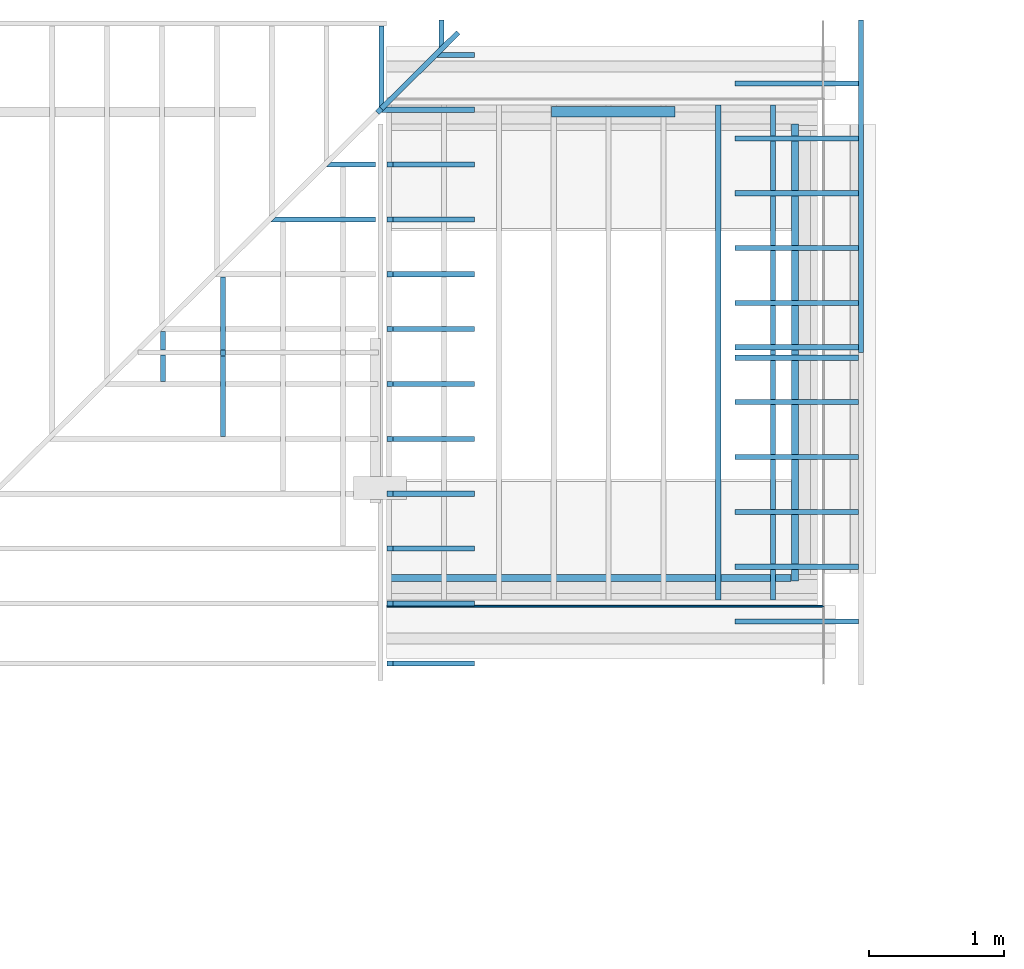
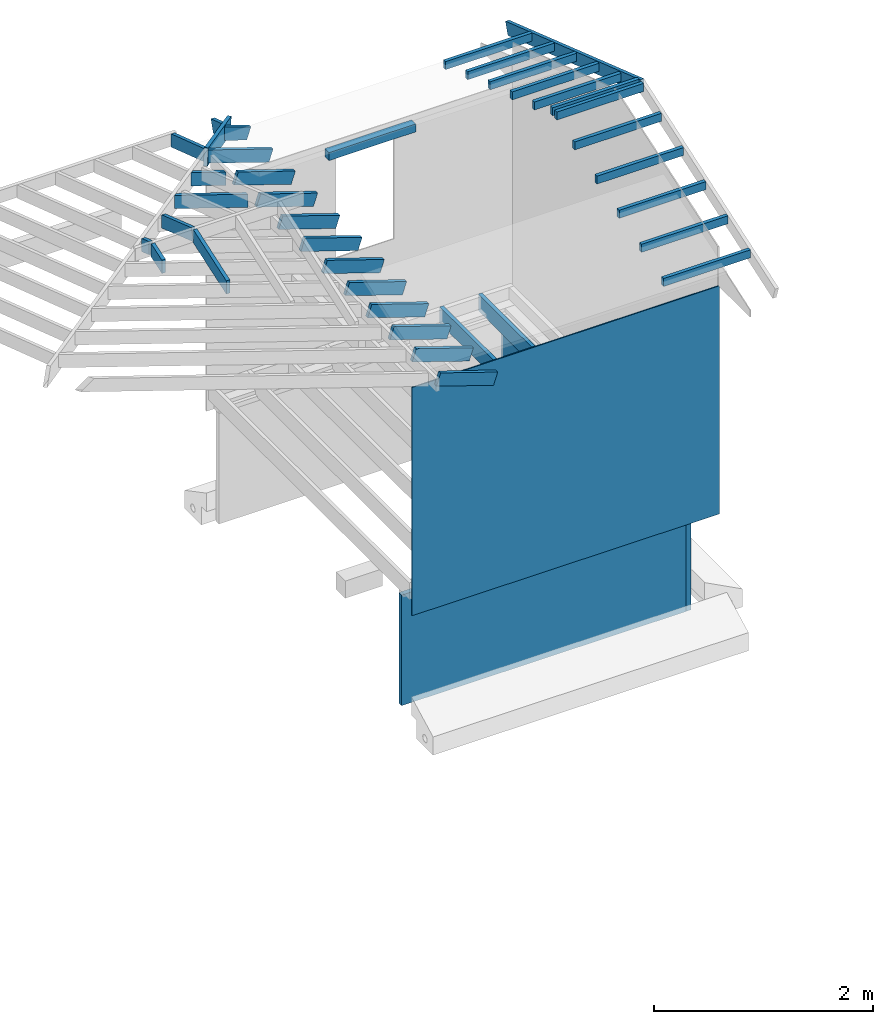
# Not in any storey, part 3 of 8: 37 beams, 3 walls.
"""IFC4 model written with IfcOpenShell, lengths in feet."""

from ifc_helpers import new_model, entity, si_unit, converted_unit, frame, origin_with_axes, origin_2d_with_axis, place, context, subcontext, project, indexed_curve, rectangle, outline, extrude, clip, halfspace, material, layer, layer_set, layer_usage, material_profile, profile_set, profile_usage, type_object, element, save


model = new_model("IFC4")

# Units and contexts
model_context = context("Model", 3, precision=1e-05, world=origin_with_axes())
plan_context = context("Plan", 2, precision=1e-05, world=origin_2d_with_axis())
context_of_model_1 = context(None, 3, precision=1e-05, world=origin_with_axes())
context_of_model_2 = context(None, 3, precision=1e-05, world=origin_with_axes())
body_context = subcontext(model_context, "Body", "Model", "MODEL_VIEW")
ifc_project = project(units=[converted_unit("PLANEANGLEUNIT", "degree", entity("IfcReal", 0.0174532925199433), si_unit("PLANEANGLEUNIT", "RADIAN"), dimensions=[0, 0, 0, 0, 0, 0, 0]), converted_unit("AREAUNIT", "square foot", entity("IfcReal", 0.09290304), si_unit("AREAUNIT", "SQUARE_METRE"), dimensions=[2, 0, 0, 0, 0, 0, 0]), converted_unit("LENGTHUNIT", "foot", entity("IfcReal", 0.3048), si_unit("LENGTHUNIT", "METRE"), dimensions=[1, 0, 0, 0, 0, 0, 0]), converted_unit("VOLUMEUNIT", "cubic foot", entity("IfcReal", 0.0283168467116885), si_unit("VOLUMEUNIT", "CUBIC_METRE"), dimensions=[3, 0, 0, 0, 0, 0, 0])], contexts=[model_context, plan_context, context_of_model_1, context_of_model_2])

# Beams
ifc_material_1 = material(Name="(2) 2X4 HEADER", Category="wood3")
ifc_material_profile_1 = material_profile(ifc_material_1, rectangle(XDim=0.25, YDim=0.291667014360428))
ifc_profile_set_1 = profile_set([ifc_material_profile_1])
ifc_profile_usage_1 = profile_usage(ifc_profile_set_1, cardinal=5)
beam_type_1 = type_object("IfcBeamType", Name="2X4", PredefinedType="BEAM", material=ifc_profile_set_1)
beam_1_placement = place(None, frame((-6.91529021175515, 8.83884473735579, 7.00261883848295), z_axis=(0.999999999999994, -7.54979012640429e-08, 7.54979012640429e-08), x_axis=(7.54979012640431e-08, 0.999999999999997, 7.16093850883224e-15)))
element("IfcBeam", 1, at=beam_1_placement, type_object=beam_type_1, material=ifc_profile_usage_1, Name="Beam", context=body_context, shape_type="SweptSolid", body=[
    extrude(rectangle(XDim=0.25, YDim=0.291667014360428), origin_with_axes(), (0.0, 0.0, 1.0), 2.99999953782462),
])
ifc_material_2 = material(Name="006")
ifc_material_profile_2 = material_profile(ifc_material_2, rectangle(XDim=0.125, YDim=0.604166686534882))
ifc_profile_set_2 = profile_set([ifc_material_profile_2])
ifc_profile_usage_2 = profile_usage(ifc_profile_set_2, cardinal=5)
beam_type_2 = type_object("IfcBeamType", Name="2x8", PredefinedType="BEAM", material=ifc_profile_set_2)
beam_2_placement = place(None, frame((-11.0968407683485, 8.86157663475497, 8.36714202650576), z_axis=(0.691535772575133, 0.685647846935964, -0.227300033526156), x_axis=(-0.704077230942166, 0.710123406788434, -2.06514179758879e-08)))
element("IfcBeam", 2, at=beam_2_placement, type_object=beam_type_2, material=ifc_profile_usage_2, Name="Beam", context=body_context, shape_type="SweptSolid", body=[
    extrude(rectangle(XDim=0.125, YDim=0.604166686534882), origin_with_axes(), (0.0, 0.0, 1.0), 2.69892431940406),
])
ifc_material_3 = material(Category="wood3")
ifc_material_profile_3 = material_profile(ifc_material_3, rectangle(XDim=0.125, YDim=0.458299994468689))
ifc_profile_set_3 = profile_set([ifc_material_profile_3])
ifc_profile_usage_3 = profile_usage(ifc_profile_set_3, cardinal=5)
beam_type_3 = type_object("IfcBeamType", Name="2x6 RAFTER", PredefinedType="BEAM", material=ifc_profile_set_3)
beam_3_placement = place(None, frame((-9.58749080893249, 10.9906905279385, 7.70176020194226), z_axis=(-1.19209318326683e-07, -0.948710682826727, 0.316145599827723), x_axis=(0.999999999999993, -1.13095140363838e-07, 3.76875242125149e-08)))
element("IfcBeam", 3, at=beam_3_placement, type_object=beam_type_3, material=ifc_profile_usage_3, Name="Beam", context=body_context, shape_type="Clipping", body=[
    clip(extrude(rectangle(XDim=0.125, YDim=0.458299994468689), origin_with_axes(), (0.0, 0.0, 1.0), 1.03234392450725), halfspace(frame((-1.5533548288458, -0.0278237141336356, 2.18816512212979), z_axis=(0.704077363014221, -0.224502399563789, 0.673701584339142), x_axis=(-0.303790687835165, -0.952738798404178, 0.0)), False)),
])
ifc_profile_usage_4 = profile_usage(ifc_profile_set_3, cardinal=5)
beam_4_placement = place(None, frame((-11.0458224777162, 11.3530398353817, 7.58101229905456), z_axis=(-1.19209318326683e-07, -0.948710682826727, 0.316145599827723), x_axis=(0.999999999999993, -1.13095140363838e-07, 3.76875313179423e-08)))
element("IfcBeam", 4, at=beam_4_placement, type_object=beam_type_3, material=ifc_profile_usage_4, Name="Beam", context=body_context, shape_type="Clipping", body=[
    clip(clip(extrude(rectangle(XDim=0.125, YDim=0.458299994468689), origin_with_axes(), (0.0, 0.0, 1.0), 2.93836754041396), halfspace(frame((0.127243242297429, 0.0117523620134889, 0.462216175994848), z_axis=(-2.36881696480395e-08, 0.316145688295364, -0.948710680007935), x_axis=(0.999999999999997, 7.49280174458948e-08, 0.0)), False)), halfspace(frame((-0.0950231661731646, -0.0278237141336356, 2.57010261217753), z_axis=(0.704077363014221, -0.224502399563789, 0.673701584339142), x_axis=(-0.303790687835165, -0.952738798404178, 0.0)), False)),
])
ifc_profile_usage_5 = profile_usage(ifc_profile_set_3, cardinal=5)
beam_5_placement = place(None, frame((-8.85837503618456, 0.884866640167286, 7.65647709838987), z_axis=(-0.948710650053447, -1.9780097822792e-07, 0.3161456981759), x_axis=(-1.62920684942943e-07, 0.999999999999977, 1.36760945679268e-07)))
element("IfcBeam", 5, at=beam_5_placement, type_object=beam_type_3, material=ifc_profile_usage_5, Name="Beam", context=body_context, shape_type="SweptSolid", body=[
    extrude(rectangle(XDim=0.125, YDim=0.458299994468689), origin_with_axes(), (0.0, 0.0, 1.0), 2.08211565102715),
])
ifc_profile_usage_6 = profile_usage(ifc_profile_set_3, cardinal=5)
beam_6_placement = place(None, frame((-8.85837503618456, -0.448466579275807, 7.65647709838987), z_axis=(-0.948710650053447, -1.9780097822792e-07, 0.3161456981759), x_axis=(-1.62920684942943e-07, 0.999999999999977, 1.36760945679268e-07)))
element("IfcBeam", 6, at=beam_6_placement, type_object=beam_type_3, material=ifc_profile_usage_6, Name="Beam", context=body_context, shape_type="SweptSolid", body=[
    extrude(rectangle(XDim=0.125, YDim=0.458299994468689), origin_with_axes(), (0.0, 0.0, 1.0), 2.08211470735415),
])
ifc_profile_usage_7 = profile_usage(ifc_profile_set_3, cardinal=5)
beam_7_placement = place(None, frame((-8.85837503618456, -1.78179970094225, 7.65647709838987), z_axis=(-0.948710650053447, -1.9780097822792e-07, 0.3161456981759), x_axis=(-1.62920684942943e-07, 0.999999999999977, 1.36760945679268e-07)))
element("IfcBeam", 7, at=beam_7_placement, type_object=beam_type_3, material=ifc_profile_usage_7, Name="Beam", context=body_context, shape_type="SweptSolid", body=[
    extrude(rectangle(XDim=0.125, YDim=0.458299994468689), origin_with_axes(), (0.0, 0.0, 1.0), 2.08211470735415),
])
ifc_profile_usage_8 = profile_usage(ifc_profile_set_3, cardinal=5)
beam_8_placement = place(None, frame((-8.85837503618456, 10.2182002518121, 7.65647709838987), z_axis=(-0.948710650053447, -1.9780097822792e-07, 0.3161456981759), x_axis=(-1.62920684942943e-07, 0.999999999999977, 1.36760945679268e-07)))
element("IfcBeam", 8, at=beam_8_placement, type_object=beam_type_3, material=ifc_profile_usage_8, Name="Beam", context=body_context, shape_type="Clipping", body=[
    clip(extrude(rectangle(XDim=0.125, YDim=0.458299994468689), origin_with_axes(), (0.0, 0.0, 1.0), 1.28196848188352), halfspace(frame((-1.40100619767907, 0.0195536521700971, 2.30658222527642), z_axis=(0.710123538970947, 0.22259096801281, 0.667965590953827), x_axis=(0.299104099787267, -0.954220486832288, 0.0)), False)),
])
ifc_profile_usage_9 = profile_usage(ifc_profile_set_3, cardinal=5)
beam_9_placement = place(None, frame((-8.85837503618456, 7.55153224849951, 7.65647709838987), z_axis=(-0.948710650053447, -1.9780097822792e-07, 0.3161456981759), x_axis=(-1.62920684942943e-07, 0.999999999999977, 1.36760945679268e-07)))
element("IfcBeam", 9, at=beam_9_placement, type_object=beam_type_3, material=ifc_profile_usage_9, Name="Beam", context=body_context, shape_type="SweptSolid", body=[
    extrude(rectangle(XDim=0.125, YDim=0.458299994468689), origin_with_axes(), (0.0, 0.0, 1.0), 2.08211642137209),
])
ifc_profile_usage_10 = profile_usage(ifc_profile_set_3, cardinal=5)
beam_10_placement = place(None, frame((-8.85837503618456, 8.88486625015579, 7.65647709838987), z_axis=(-0.948710650053447, -1.9780097822792e-07, 0.3161456981759), x_axis=(-1.62920684942943e-07, 0.999999999999977, 1.36760945679268e-07)))
element("IfcBeam", 10, at=beam_10_placement, type_object=beam_type_3, material=ifc_profile_usage_10, Name="Beam", context=body_context, shape_type="Clipping", body=[
    clip(extrude(rectangle(XDim=0.125, YDim=0.458299994468689), origin_with_axes(), (0.0, 0.0, 1.0), 2.6994550511993), halfspace(frame((-0.0676714260316896, 0.0195536521700971, 2.30658222527642), z_axis=(0.710123538970947, 0.22259096801281, 0.667965590953827), x_axis=(0.299104099787267, -0.954220486832288, 0.0)), False)),
])
ifc_profile_usage_11 = profile_usage(ifc_profile_set_3, cardinal=5)
beam_11_placement = place(None, frame((-8.85837503618456, 4.88486659182651, 7.65647709838987), z_axis=(-0.948710650053447, -1.9780097822792e-07, 0.3161456981759), x_axis=(-1.62920684942943e-07, 0.999999999999977, 1.36760945679268e-07)))
element("IfcBeam", 11, at=beam_11_placement, type_object=beam_type_3, material=ifc_profile_usage_11, Name="Beam", context=body_context, shape_type="SweptSolid", body=[
    extrude(rectangle(XDim=0.125, YDim=0.458299994468689), origin_with_axes(), (0.0, 0.0, 1.0), 2.08211642137213),
])
ifc_profile_usage_12 = profile_usage(ifc_profile_set_3, cardinal=5)
beam_12_placement = place(None, frame((-8.85837503618456, 3.55153298127683, 7.65647709838987), z_axis=(-0.948710650053447, -1.9780097822792e-07, 0.3161456981759), x_axis=(-1.62920684942943e-07, 0.999999999999977, 1.36760945679268e-07)))
element("IfcBeam", 12, at=beam_12_placement, type_object=beam_type_3, material=ifc_profile_usage_12, Name="Beam", context=body_context, shape_type="SweptSolid", body=[
    extrude(rectangle(XDim=0.125, YDim=0.458299994468689), origin_with_axes(), (0.0, 0.0, 1.0), 2.08211565102715),
])
ifc_profile_usage_13 = profile_usage(ifc_profile_set_3, cardinal=5)
beam_13_placement = place(None, frame((-8.85837503618456, 2.21820034849362, 7.65647709838987), z_axis=(-0.948710650053447, -1.9780097822792e-07, 0.3161456981759), x_axis=(-1.62920684942943e-07, 0.999999999999977, 1.36760945679268e-07)))
element("IfcBeam", 13, at=beam_13_placement, type_object=beam_type_3, material=ifc_profile_usage_13, Name="Beam", context=body_context, shape_type="SweptSolid", body=[
    extrude(rectangle(XDim=0.125, YDim=0.458299994468689), origin_with_axes(), (0.0, 0.0, 1.0), 2.08211565102715),
])
ifc_profile_usage_14 = profile_usage(ifc_profile_set_3, cardinal=5)
beam_14_placement = place(None, frame((-8.85837503618456, -3.11513272483205, 7.65647709838987), z_axis=(-0.948710650053447, -1.9780097822792e-07, 0.3161456981759), x_axis=(-1.62920684942943e-07, 0.999999999999977, 1.36760945679268e-07)))
element("IfcBeam", 14, at=beam_14_placement, type_object=beam_type_3, material=ifc_profile_usage_14, Name="Beam", context=body_context, shape_type="SweptSolid", body=[
    extrude(rectangle(XDim=0.125, YDim=0.458299994468689), origin_with_axes(), (0.0, 0.0, 1.0), 2.08211470735415),
])
ifc_profile_usage_15 = profile_usage(ifc_profile_set_3, cardinal=5)
beam_15_placement = place(None, frame((-8.85837503618456, -4.57346634914869, 7.65647709838987), z_axis=(-0.94871061429891, -1.66479323476969e-07, 0.316145805470447), x_axis=(-1.62920684942944e-07, 0.999999999999986, 3.7687520659801e-08)))
element("IfcBeam", 15, at=beam_15_placement, type_object=beam_type_3, material=ifc_profile_usage_15, Name="Beam", context=body_context, shape_type="SweptSolid", body=[
    extrude(rectangle(XDim=0.125, YDim=0.458299994468689), origin_with_axes(), (0.0, 0.0, 1.0), 2.08211495771642),
])
ifc_profile_usage_16 = profile_usage(ifc_profile_set_3, cardinal=5)
beam_16_placement = place(None, frame((-10.7543893999315, 7.55153224849951, 8.28829963063318), z_axis=(-0.948710682826718, -1.82218031427762e-07, 0.316145599827721), x_axis=(-1.62920684942944e-07, 0.999999999999983, 8.74705818887363e-08)))
element("IfcBeam", 16, at=beam_16_placement, type_object=beam_type_3, material=ifc_profile_usage_16, Name="Beam", context=body_context, shape_type="Clipping", body=[
    clip(clip(extrude(rectangle(XDim=0.125, YDim=0.458299994468689), origin_with_axes(), (0.0, 0.0, 1.0), 2.11842334462929), halfspace(frame((-12.5391229869812, 0.0239981431880687, 0.450306198024374), z_axis=(-3.13916473260178e-07, -0.316145569086075, -0.94871062040329), x_axis=(-0.999999999999507, 9.92949147342172e-07, 0.0)), False)), halfspace(frame((1.2656610234203, 0.0195532610635041, 0.308064250104384), z_axis=(0.710123538970947, 0.22259096801281, 0.667965531349182), x_axis=(0.299104099787267, -0.954220486832288, 0.0)), False)),
])
ifc_profile_usage_17 = profile_usage(ifc_profile_set_3, cardinal=5)
beam_17_placement = place(None, frame((-10.7543893999315, 6.21819942016301, 8.28829963063318), z_axis=(-0.948710682826718, -1.82218031427762e-07, 0.316145599827721), x_axis=(-1.62920684942944e-07, 0.999999999999983, 8.74705818887363e-08)))
element("IfcBeam", 17, at=beam_17_placement, type_object=beam_type_3, material=ifc_profile_usage_17, Name="Beam", context=body_context, shape_type="Clipping", body=[
    clip(clip(extrude(rectangle(XDim=0.125, YDim=0.458299994468689), origin_with_axes(), (0.0, 0.0, 1.0), 3.53590986171043), halfspace(frame((-11.2057897675382, 0.0239985342946617, 0.450306198024374), z_axis=(-3.13916473260178e-07, -0.316145569086075, -0.94871062040329), x_axis=(-0.999999999999507, 9.92949147342172e-07, 0.0)), False)), halfspace(frame((2.59899424286339, 0.0195536521700971, 0.308064250104384), z_axis=(0.710123538970947, 0.22259096801281, 0.667965531349182), x_axis=(0.299104099787267, -0.954220486832288, 0.0)), False)),
])
ifc_profile_usage_18 = profile_usage(ifc_profile_set_3, cardinal=5)
beam_18_placement = place(None, frame((-8.85837503618456, 6.2181998112696, 7.65647709838987), z_axis=(-0.948710650053447, -1.9780097822792e-07, 0.3161456981759), x_axis=(-1.62920684942943e-07, 0.999999999999977, 1.36760945679268e-07)))
element("IfcBeam", 18, at=beam_18_placement, type_object=beam_type_3, material=ifc_profile_usage_18, Name="Beam", context=body_context, shape_type="SweptSolid", body=[
    extrude(rectangle(XDim=0.125, YDim=0.458299994468689), origin_with_axes(), (0.0, 0.0, 1.0), 2.08211642137213),
])
ifc_material_4 = material(Category="wood3")
ifc_material_profile_4 = material_profile(ifc_material_4, rectangle(XDim=0.125, YDim=0.291666656732559))
ifc_profile_set_4 = profile_set([ifc_material_profile_4])
ifc_profile_usage_19 = profile_usage(ifc_profile_set_4, cardinal=5)
beam_type_4 = type_object("IfcBeamType", Name="2x4", PredefinedType="BEAM", material=ifc_profile_set_4)
beam_19_placement = place(None, frame((-2.45551600700288, -3.55546008257728, 8.31366993310883), z_axis=(0.999999999999998, 4.37113882867378e-08, -4.37113882867378e-08), x_axis=(-4.37113882867379e-08, 0.999999999999999, 0.0)))
element("IfcBeam", 19, at=beam_19_placement, type_object=beam_type_4, material=ifc_profile_usage_19, Name="Beam", context=body_context, shape_type="SweptSolid", body=[
    extrude(rectangle(XDim=0.125, YDim=0.291666656732559), origin_with_axes(), (0.0, 0.0, 1.0), 2.99999932396489),
])
ifc_profile_usage_20 = profile_usage(ifc_profile_set_4, cardinal=5)
beam_20_placement = place(None, frame((-2.45551600700288, -2.22212999198693, 8.75367032574231), z_axis=(0.999999999999998, 4.37113882867378e-08, -4.37113882867378e-08), x_axis=(-4.37113882867379e-08, 0.999999999999999, 0.0)))
element("IfcBeam", 20, at=beam_20_placement, type_object=beam_type_4, material=ifc_profile_usage_20, Name="Beam", context=body_context, shape_type="SweptSolid", body=[
    extrude(rectangle(XDim=0.125, YDim=0.291666656732559), origin_with_axes(), (0.0, 0.0, 1.0), 2.9999993239649),
])
ifc_profile_usage_21 = profile_usage(ifc_profile_set_4, cardinal=5)
beam_21_placement = place(None, frame((-2.45551620255618, -0.888799901396584, 9.19367071837578), z_axis=(0.999999999999998, 4.37113882867378e-08, -4.37113882867378e-08), x_axis=(-4.37113882867379e-08, 0.999999999999999, 0.0)))
element("IfcBeam", 21, at=beam_21_placement, type_object=beam_type_4, material=ifc_profile_usage_21, Name="Beam", context=body_context, shape_type="SweptSolid", body=[
    extrude(rectangle(XDim=0.125, YDim=0.291666656732559), origin_with_axes(), (0.0, 0.0, 1.0), 2.99999932396489),
])
ifc_profile_usage_22 = profile_usage(ifc_profile_set_4, cardinal=5)
beam_22_placement = place(None, frame((-2.45551620255618, 0.444530189193766, 9.63367032879607), z_axis=(0.999999999999998, 4.37113882867378e-08, -4.37113882867378e-08), x_axis=(-4.37113882867379e-08, 0.999999999999999, 0.0)))
element("IfcBeam", 22, at=beam_22_placement, type_object=beam_type_4, material=ifc_profile_usage_22, Name="Beam", context=body_context, shape_type="SweptSolid", body=[
    extrude(rectangle(XDim=0.125, YDim=0.291666656732559), origin_with_axes(), (0.0, 0.0, 1.0), 2.99999932396489),
])
ifc_profile_usage_23 = profile_usage(ifc_profile_set_4, cardinal=5)
beam_23_placement = place(None, frame((-2.45551620255618, 1.77786027978411, 10.0736699392164), z_axis=(0.999999999999998, 4.37113882867378e-08, -4.37113882867378e-08), x_axis=(-4.37113882867379e-08, 0.999999999999999, 0.0)))
element("IfcBeam", 23, at=beam_23_placement, type_object=beam_type_4, material=ifc_profile_usage_23, Name="Beam", context=body_context, shape_type="SweptSolid", body=[
    extrude(rectangle(XDim=0.125, YDim=0.291666656732559), origin_with_axes(), (0.0, 0.0, 1.0), 2.9999993239649),
])
ifc_profile_usage_24 = profile_usage(ifc_profile_set_4, cardinal=5)
beam_24_placement = place(None, frame((-2.45551620255618, 3.11119037037446, 10.5136703318498), z_axis=(0.999999999999998, 4.37113882867378e-08, -4.37113882867378e-08), x_axis=(-4.37113882867379e-08, 0.999999999999999, 0.0)))
element("IfcBeam", 24, at=beam_24_placement, type_object=beam_type_4, material=ifc_profile_usage_24, Name="Beam", context=body_context, shape_type="SweptSolid", body=[
    extrude(rectangle(XDim=0.125, YDim=0.291666656732559), origin_with_axes(), (0.0, 0.0, 1.0), 2.9999993239649),
])
ifc_profile_usage_25 = profile_usage(ifc_profile_set_4, cardinal=5)
beam_25_placement = place(None, frame((-2.45551561589629, 9.52241771177357, 8.31366993310883), z_axis=(0.999999999999998, 4.37113882867378e-08, -4.37113882867378e-08), x_axis=(-4.37113882867379e-08, 0.999999999999999, 0.0)))
element("IfcBeam", 25, at=beam_25_placement, type_object=beam_type_4, material=ifc_profile_usage_25, Name="Beam", context=body_context, shape_type="SweptSolid", body=[
    extrude(rectangle(XDim=0.125, YDim=0.291666656732559), origin_with_axes(), (0.0, 0.0, 1.0), 2.99999932396489),
])
ifc_profile_usage_26 = profile_usage(ifc_profile_set_4, cardinal=5)
beam_26_placement = place(None, frame((-2.45551542034299, 8.18908762118322, 8.75367032574231), z_axis=(0.999999999999998, 4.37113882867378e-08, -4.37113882867378e-08), x_axis=(-4.37113882867379e-08, 0.999999999999999, 0.0)))
element("IfcBeam", 26, at=beam_26_placement, type_object=beam_type_4, material=ifc_profile_usage_26, Name="Beam", context=body_context, shape_type="SweptSolid", body=[
    extrude(rectangle(XDim=0.125, YDim=0.291666656732559), origin_with_axes(), (0.0, 0.0, 1.0), 2.99999932396489),
])
ifc_profile_usage_27 = profile_usage(ifc_profile_set_4, cardinal=5)
beam_27_placement = place(None, frame((-2.45551542034299, 6.85575753059287, 9.19367071837578), z_axis=(0.999999999999998, 4.37113882867378e-08, -4.37113882867378e-08), x_axis=(-4.37113882867379e-08, 0.999999999999999, 0.0)))
element("IfcBeam", 27, at=beam_27_placement, type_object=beam_type_4, material=ifc_profile_usage_27, Name="Beam", context=body_context, shape_type="SweptSolid", body=[
    extrude(rectangle(XDim=0.125, YDim=0.291666656732559), origin_with_axes(), (0.0, 0.0, 1.0), 2.99999932396489),
])
ifc_profile_usage_28 = profile_usage(ifc_profile_set_4, cardinal=5)
beam_28_placement = place(None, frame((-2.4555152247897, 5.52242744000252, 9.63367032879607), z_axis=(0.999999999999998, 4.37113882867378e-08, -4.37113882867378e-08), x_axis=(-4.37113882867379e-08, 0.999999999999999, 0.0)))
element("IfcBeam", 28, at=beam_28_placement, type_object=beam_type_4, material=ifc_profile_usage_28, Name="Beam", context=body_context, shape_type="SweptSolid", body=[
    extrude(rectangle(XDim=0.125, YDim=0.291666656732559), origin_with_axes(), (0.0, 0.0, 1.0), 2.99999932396489),
])
ifc_profile_usage_29 = profile_usage(ifc_profile_set_4, cardinal=5)
beam_29_placement = place(None, frame((-2.4555152247897, 4.18909734941217, 10.0736699392164), z_axis=(0.999999999999998, 4.37113882867378e-08, -4.37113882867378e-08), x_axis=(-4.37113882867379e-08, 0.999999999999999, 0.0)))
element("IfcBeam", 29, at=beam_29_placement, type_object=beam_type_4, material=ifc_profile_usage_29, Name="Beam", context=body_context, shape_type="SweptSolid", body=[
    extrude(rectangle(XDim=0.125, YDim=0.291666656732559), origin_with_axes(), (0.0, 0.0, 1.0), 2.99999932396489),
])
ifc_profile_usage_30 = profile_usage(ifc_profile_set_4, cardinal=5)
beam_30_placement = place(None, frame((-2.4555152247897, 2.85576725882182, 10.5136703318498), z_axis=(0.999999999999998, 4.37113882867378e-08, -4.37113882867378e-08), x_axis=(-4.37113882867379e-08, 0.999999999999999, 0.0)))
element("IfcBeam", 30, at=beam_30_placement, type_object=beam_type_4, material=ifc_profile_usage_30, Name="Beam", context=body_context, shape_type="SweptSolid", body=[
    extrude(rectangle(XDim=0.125, YDim=0.291666656732559), origin_with_axes(), (0.0, 0.0, 1.0), 2.9999993239649),
])
ifc_material_profile_5 = material_profile(ifc_material_3, rectangle(XDim=0.125, YDim=0.458299994468689))
ifc_profile_set_5 = profile_set([ifc_material_profile_5])
ifc_profile_usage_31 = profile_usage(ifc_profile_set_5, cardinal=5)
beam_type_5 = type_object("IfcBeamType", Name="2X6 BARGE RAFTER", PredefinedType="BEAM", material=ifc_profile_set_5)
beam_31_placement = place(None, frame((0.60698335252096, 10.9922221013567, 7.70260499218317), z_axis=(-1.19209299780676e-07, -0.946459136166883, 0.322823641585037), x_axis=(0.999999999999993, -1.12826732845405e-07, 3.84836056355195e-08)))
element("IfcBeam", 31, at=beam_31_placement, type_object=beam_type_5, material=ifc_profile_usage_31, Name="Beam", context=body_context, shape_type="Clipping", body=[
    clip(extrude(rectangle(XDim=0.125, YDim=0.458299994468689), origin_with_axes(), (0.0, 0.0, 1.0), 9.29358308608242), halfspace(frame((-0.606982472531126, 0.229148668410584, 8.5383825727648), z_axis=(-1.64691172699349e-07, -0.322770535945892, 0.946477353572845), x_axis=(-0.99999999999987, 5.10242275419266e-07, 0.0)), False)),
])
ifc_profile_usage_32 = profile_usage(ifc_profile_set_5, cardinal=5)
beam_32_placement = place(None, frame((-16.3513343791011, 3.92279404354846, 10.1138850835365), z_axis=(-1.19209291908779e-07, -0.946459133272804, 0.322823650069941), x_axis=(0.999999999999993, -1.12826725739978e-07, 3.84835772138101e-08)))
element("IfcBeam", 32, at=beam_32_placement, type_object=beam_type_5, material=ifc_profile_usage_32, Name="Beam", context=body_context, shape_type="Clipping", body=[
    clip(clip(extrude(rectangle(XDim=0.125, YDim=0.458299994468689), origin_with_axes(), (0.0, 0.0, 1.0), 1.38471427914114), halfspace(frame((5.65944537715962, -1.887579758962, -0.185528452315043), z_axis=(-2.6183835188931e-07, 0.322823762893677, -0.946459233760834), x_axis=(0.999999999999671, 8.11087602542633e-07, 0.0)), False)), halfspace(frame((-0.609198531375469, 0.0204070620336558, 0.933375102015618), z_axis=(-6.38255670537546e-09, -0.32282367348671, 0.946459233760834), x_axis=(-1.0, 1.97710305332927e-08, 0.0)), False)),
])
ifc_profile_usage_33 = profile_usage(ifc_profile_set_5, cardinal=5)
beam_33_placement = place(None, frame((-16.3513265569692, 1.84692031755222, 10.0457472751147), z_axis=(8.54136783382466e-07, 0.94649584365125, 0.322716002005138), x_axis=(-0.999999999999619, 8.6625152562159e-07, 1.06078672956715e-07)))
element("IfcBeam", 33, at=beam_33_placement, type_object=beam_type_5, material=ifc_profile_usage_33, Name="Beam", context=body_context, shape_type="Clipping", body=[
    clip(clip(extrude(rectangle(XDim=0.125, YDim=0.458299994468689), origin_with_axes(), (0.0, 0.0, 1.0), 1.59307535356382), halfspace(frame((-5.59693520150472, -1.80340599356674, -0.156581088939677), z_axis=(-1.0152631375604e-06, 0.322715908288956, -0.946495831012726), x_axis=(0.999999999995051, 3.14599656068494e-06, 0.0)), False)), halfspace(frame((0.609208455705267, 0.0213508098814001, 1.14205393578437), z_axis=(7.47042236071138e-07, -0.322715997695923, 0.946495831012726), x_axis=(-0.999999999997321, -2.31485963324642e-06, 0.0)), False)),
])
ifc_profile_usage_34 = profile_usage(ifc_profile_set_5, cardinal=5)
beam_34_placement = place(None, frame((-14.8930074035965, 5.25612765409815, 9.65910399053979), z_axis=(-1.19209291908779e-07, -0.946459133272804, 0.322823650069941), x_axis=(0.999999999999993, -1.12826725739978e-07, 3.84835772138101e-08)))
element("IfcBeam", 34, at=beam_34_placement, type_object=beam_type_5, material=ifc_profile_usage_34, Name="Beam", context=body_context, shape_type="Clipping", body=[
    clip(extrude(rectangle(XDim=0.125, YDim=0.458299994468689), origin_with_axes(), (0.0, 0.0, 1.0), 2.41333530858582), halfspace(frame((4.20111801054847, -1.4571489624464, -0.0387141719372488), z_axis=(-2.6183835188931e-07, 0.322823762893677, -0.946459233760834), x_axis=(0.999999999999671, 8.11087602542633e-07, 0.0)), False)),
])
ifc_profile_usage_35 = profile_usage(ifc_profile_set_5, cardinal=5)
beam_35_placement = place(None, frame((-14.8930027103174, 0.51358641367259, 9.59113435795301), z_axis=(8.54136783382466e-07, 0.94649584365125, 0.322716002005138), x_axis=(-0.999999999999619, 8.6625152562159e-07, 1.06078672956715e-07)))
element("IfcBeam", 35, at=beam_35_placement, type_object=beam_type_5, material=ifc_profile_usage_35, Name="Beam", context=body_context, shape_type="Clipping", body=[
    clip(extrude(rectangle(XDim=0.125, YDim=0.458299994468689), origin_with_axes(), (0.0, 0.0, 1.0), 2.62161099133974), halfspace(frame((-4.13861252817269, -1.3731145287749, -0.00987103617728108), z_axis=(-1.0152631375604e-06, 0.322715908288956, -0.946495831012726), x_axis=(0.999999999995051, 3.14599656068494e-06, 0.0)), False)),
])
ifc_material_5 = material(Category="wood3")
ifc_material_profile_6 = material_profile(ifc_material_5, rectangle(XDim=0.125, YDim=0.604166686534882))
ifc_profile_set_6 = profile_set([ifc_material_profile_6])
ifc_profile_usage_36 = profile_usage(ifc_profile_set_6, cardinal=5)
beam_type_6 = type_object("IfcBeamType", Name="2x8 JOIST", PredefinedType="BEAM", material=ifc_profile_set_6)
beam_36_placement = place(None, frame((-1.52539422740461, -3.03462421487323, -0.364615476819787), z_axis=(1.50995802528084e-07, 0.999999999999986, 7.54979012640422e-08), x_axis=(-0.999999999999989, 1.50995802528085e-07, 7.16093766179923e-15)))
element("IfcBeam", 36, at=beam_36_placement, type_object=beam_type_6, material=ifc_profile_usage_36, Name="Beam", context=body_context, shape_type="SweptSolid", body=[
    extrude(rectangle(XDim=0.125, YDim=0.604166686534882), origin_with_axes(), (0.0, 0.0, 1.0), 12.0362043017855),
])
ifc_profile_usage_37 = profile_usage(ifc_profile_set_6, cardinal=5)
beam_37_placement = place(None, frame((-2.8587244157716, -3.03462401931993, -0.364615476819787), z_axis=(1.50995802528084e-07, 0.999999999999986, 7.54979012640422e-08), x_axis=(-0.999999999999989, 1.50995802528085e-07, 1.00485924106347e-14)))
element("IfcBeam", 37, at=beam_37_placement, type_object=beam_type_6, material=ifc_profile_usage_37, Name="Beam", context=body_context, shape_type="SweptSolid", body=[
    extrude(rectangle(XDim=0.125, YDim=0.604166686534882), origin_with_axes(), (0.0, 0.0, 1.0), 12.0362043017855),
])

# Walls
ifc_material_6 = material(Name="SIDING", Category="siding")
ifc_layer_1 = layer(ifc_material_6, 0.0416669994592667)
ifc_layer_set_1 = layer_set([ifc_layer_1])
ifc_layer_usage_1 = layer_usage(ifc_layer_set_1, "AXIS2", "POSITIVE", 0.0)
wall_type_1 = type_object("IfcWallType", PredefinedType="STANDARD", material=ifc_layer_set_1)
wall_1_placement = place(None, frame((-10.9212237393136, -3.20128803178081, -1.16348227490903), z_axis=(0.0, 0.0, 1.0), x_axis=(1.0, 0.0, 0.0)))
element("IfcWall", 38, at=wall_1_placement, type_object=wall_type_1, material=ifc_layer_usage_1, Name="Wall", context=body_context, shape_type="Clipping", body=[
    clip(extrude(outline(indexed_curve([(0.0, 0.0), (0.0, 0.0416669994592667), (10.6354101016816, 0.0416669994592667), (10.6354101016816, 0.0), (0.0, 0.0)], self_intersect=False)), origin_with_axes(), (0.0, 0.0, 1.0), 8.34589007645454), halfspace(frame((10.6354108632706, 0.0, 1.16348227490903), z_axis=(0.707106173038483, 0.707107365131378, 0.0), x_axis=(0.707107377232754, -0.707106185139838, 0.0)), False)),
])
ifc_material_7 = material(Category="InsulationBattVert")
ifc_layer_2 = layer(ifc_material_7, 0.166666999459267, Category="Materials")
ifc_layer_set_2 = layer_set([ifc_layer_2], Name="poche")
ifc_layer_usage_2 = layer_usage(ifc_layer_set_2, "AXIS2", "POSITIVE", 0.0)
wall_type_2 = type_object("IfcWallType", Name="EPS INSULATION", PredefinedType="STANDARD", material=ifc_layer_set_2)
wall_2_placement = place(None, frame((-10.9212276503796, -2.5762910917988, -4.83333204049138), z_axis=(0.0, 0.0, 1.0), x_axis=(1.0, 0.0, 0.0)))
element("IfcWall", 39, at=wall_2_placement, type_object=wall_type_2, material=ifc_layer_usage_2, Name="Wall", context=body_context, shape_type="SweptSolid", body=[
    extrude(outline(indexed_curve([(0.0, 0.0), (0.0, 0.166666999459267), (9.83333899973922, 0.166666999459267), (9.83333899973922, 0.0), (0.0, 0.0)], self_intersect=False)), origin_with_axes(), (0.0, 0.0, 1.0), 4.041670110282),
])
ifc_layer_usage_3 = layer_usage(ifc_layer_set_2, "AXIS2", "POSITIVE", 0.0)
wall_3_placement = place(None, frame((-0.910809522695116, -2.56587122994771, -4.83333204049138), z_axis=(0.0, 0.0, 1.0), x_axis=(1.94707183709394e-07, 0.999999999999981, 0.0)))
element("IfcWall", 40, at=wall_3_placement, type_object=wall_type_2, material=ifc_layer_usage_3, Name="Wall", context=body_context, shape_type="SweptSolid", body=[
    extrude(outline(indexed_curve([(0.0, 0.0), (0.0, 0.166666999459267), (11.0987015986335, 0.166666999459267), (11.0987015986335, 0.0), (0.0, 0.0)], self_intersect=False)), origin_with_axes(), (0.0, 0.0, 1.0), 4.041670110282),
])

save(model, "model.ifc")
